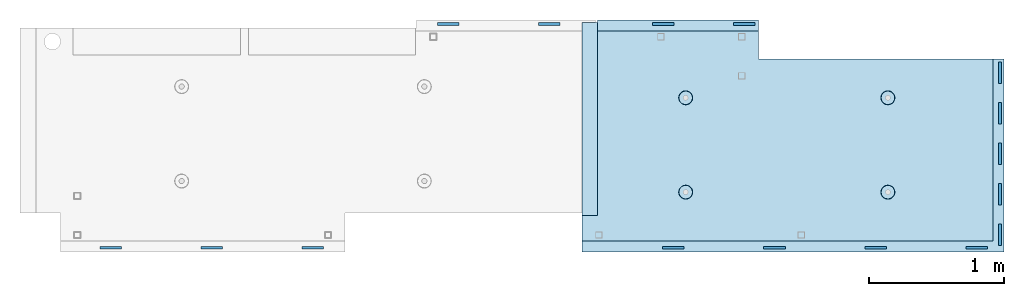
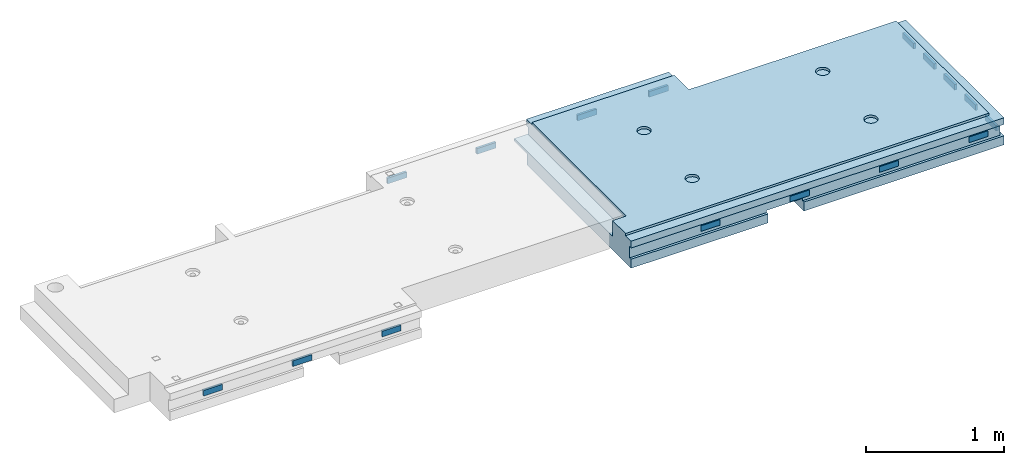
# One storey, part 3 of 3: 16 plates, 1 slab, 18 elements without a shape of their own.
"""IFC2X3 building model written with IfcOpenShell, lengths in millimetres."""

from ifc_helpers import new_model, si_unit, frame, origin_with_axes, place, context, subcontext, project, spatial, faceted_brep, material, type_object, element, aggregate, save


model = new_model("IFC2X3")

# Units and contexts
model_context = context("Model", 3, precision=1e-05, world=origin_with_axes())
body_context = subcontext(model_context, "Body", "Model", "MODEL_VIEW")
ifc_project = project(units=[si_unit("LENGTHUNIT", "METRE", prefix="MILLI"), si_unit("AREAUNIT", "SQUARE_METRE"), si_unit("VOLUMEUNIT", "CUBIC_METRE"), si_unit("MASSUNIT", "GRAM", prefix="KILO"), si_unit("TIMEUNIT", "SECOND"), si_unit("PLANEANGLEUNIT", "RADIAN"), si_unit("SOLIDANGLEUNIT", "STERADIAN"), si_unit("THERMODYNAMICTEMPERATUREUNIT", "DEGREE_CELSIUS"), si_unit("LUMINOUSINTENSITYUNIT", "LUMEN")], contexts=[model_context])

# Site, building, storey
site_placement = place(None, origin_with_axes())
site = spatial("IfcSite", under=ifc_project, at=site_placement, CompositionType="ELEMENT")
building_placement = place(site_placement, origin_with_axes())
building = spatial("IfcBuilding", under=site, at=building_placement, Name="Undefined", CompositionType="ELEMENT")
storey_placement = place(building_placement, origin_with_axes())
storey = spatial("IfcBuildingStorey", under=building, at=storey_placement, Name="3", CompositionType="ELEMENT", Elevation=0.0)

# Assemblies, plates
assembly_1_placement = place(storey_placement, origin_with_axes())
assembly_1 = element("IfcElementAssembly", 1, at=assembly_1_placement, inside=storey, AssemblyPlace="NOTDEFINED", PredefinedType="REINFORCEMENT_UNIT")
assembly_2_placement = place(assembly_1_placement, origin_with_axes())
assembly_2 = element("IfcElementAssembly", 2, at=assembly_2_placement, Name="Steel Assembly", AssemblyPlace="NOTDEFINED", PredefinedType="RIGID_FRAME")
ifc_material_1 = material(Name="STEEL/Steel_Undefined")
plate_type = type_object("IfcPlateType", PredefinedType="NOTDEFINED")
plate_1_placement = place(assembly_2_placement, frame((26530.0042242562, 15347.4967352626, 90645.0), z_axis=(0.999999999999282, 1.19800000174933e-06, 0.0), x_axis=(0.0, 0.0, -1.0)))
plate_1 = element("IfcPlate", 3, at=plate_1_placement, type_object=plate_type, material=ifc_material_1, Name="VL_080", context=body_context, shape_type="Brep", body=[
    faceted_brep([(0.0, -80.0, 0.0), (0.0, -80.0, 20.0), (0.0, 80.0, 20.0), (0.0, 80.0, 0.0), (50.0, -80.0, 20.0), (50.0, 80.0, 20.0), (50.0, -80.0, 0.0), (50.0, 80.0, 0.0)], [[[0, 1, 2, 3]], [[1, 4, 5, 2]], [[4, 6, 7, 5]], [[6, 0, 3, 7]], [[5, 7, 3, 2]], [[6, 4, 1, 0]]]),
])
aggregate(assembly_2, [plate_1])
assembly_3_placement = place(assembly_1_placement, origin_with_axes())
assembly_3 = element("IfcElementAssembly", 4, at=assembly_3_placement, Name="Steel Assembly", AssemblyPlace="NOTDEFINED", PredefinedType="RIGID_FRAME")
plate_2_placement = place(assembly_3_placement, frame((26530.0042242563, 15647.4967352626, 90645.0), z_axis=(0.999999999999282, 1.19800000174933e-06, 0.0), x_axis=(0.0, 0.0, -1.0)))
plate_2 = element("IfcPlate", 5, at=plate_2_placement, type_object=plate_type, material=ifc_material_1, Name="VL_080", context=body_context, shape_type="Brep", body=[
    faceted_brep([(0.0, -80.0, 0.0), (0.0, -80.0, 20.0), (0.0, 80.0, 20.0), (0.0, 80.0, 0.0), (50.0, -80.0, 20.0), (50.0, 80.0, 20.0), (50.0, -80.0, 0.0), (50.0, 80.0, 0.0)], [[[0, 1, 2, 3]], [[1, 4, 5, 2]], [[4, 6, 7, 5]], [[6, 0, 3, 7]], [[5, 7, 3, 2]], [[6, 4, 1, 0]]]),
])
aggregate(assembly_3, [plate_2])
assembly_4_placement = place(assembly_1_placement, origin_with_axes())
assembly_4 = element("IfcElementAssembly", 6, at=assembly_4_placement, Name="Steel Assembly", AssemblyPlace="NOTDEFINED", PredefinedType="RIGID_FRAME")
plate_3_placement = place(assembly_4_placement, frame((26530.0042242564, 15947.4967352626, 90645.0), z_axis=(0.999999999999282, 1.19800000174933e-06, 0.0), x_axis=(0.0, 0.0, -1.0)))
plate_3 = element("IfcPlate", 7, at=plate_3_placement, type_object=plate_type, material=ifc_material_1, Name="VL_080", context=body_context, shape_type="Brep", body=[
    faceted_brep([(0.0, -80.0, 0.0), (0.0, -80.0, 20.0), (0.0, 80.0, 20.0), (0.0, 80.0, 0.0), (50.0, -80.0, 20.0), (50.0, 80.0, 20.0), (50.0, -80.0, 0.0), (50.0, 80.0, 0.0)], [[[0, 1, 2, 3]], [[1, 4, 5, 2]], [[4, 6, 7, 5]], [[6, 0, 3, 7]], [[5, 7, 3, 2]], [[6, 4, 1, 0]]]),
])
aggregate(assembly_4, [plate_3])

assembly_5_placement = place(storey_placement, origin_with_axes())
assembly_5 = element("IfcElementAssembly", 8, at=assembly_5_placement, inside=storey, AssemblyPlace="NOTDEFINED", PredefinedType="REINFORCEMENT_UNIT")
assembly_6_placement = place(assembly_5_placement, origin_with_axes())
assembly_6 = element("IfcElementAssembly", 9, at=assembly_6_placement, Name="Steel Assembly", AssemblyPlace="NOTDEFINED", PredefinedType="RIGID_FRAME")
plate_4_placement = place(assembly_6_placement, frame((19942.4996278758, 15260.0015053437, 90645.0000000001), z_axis=(0.0, -1.0, 0.0), x_axis=(0.0, 0.0, -1.0)))
plate_4 = element("IfcPlate", 10, at=plate_4_placement, type_object=plate_type, material=ifc_material_1, Name="VL_080", context=body_context, shape_type="Brep", body=[
    faceted_brep([(0.0, -80.0, 0.0), (0.0, -80.0, 20.0), (0.0, 80.0, 20.0), (0.0, 80.0, 0.0), (50.0, -80.0, 20.0), (50.0, 80.0, 20.0), (50.0, -80.0, 0.0), (50.0, 80.0, 0.0)], [[[0, 1, 2, 3]], [[1, 4, 5, 2]], [[4, 6, 7, 5]], [[6, 0, 3, 7]], [[5, 7, 3, 2]], [[6, 4, 1, 0]]]),
])
aggregate(assembly_6, [plate_4])
assembly_7_placement = place(assembly_5_placement, origin_with_axes())
assembly_7 = element("IfcElementAssembly", 11, at=assembly_7_placement, Name="Steel Assembly", AssemblyPlace="NOTDEFINED", PredefinedType="RIGID_FRAME")
plate_5_placement = place(assembly_7_placement, frame((20692.4996278758, 15260.0015053437, 90645.0000000001), z_axis=(0.0, -1.0, 0.0), x_axis=(0.0, 0.0, -1.0)))
plate_5 = element("IfcPlate", 12, at=plate_5_placement, type_object=plate_type, material=ifc_material_1, Name="VL_080", context=body_context, shape_type="Brep", body=[
    faceted_brep([(0.0, -80.0, 0.0), (0.0, -80.0, 20.0), (0.0, 80.0, 20.0), (0.0, 80.0, 0.0), (50.0, -80.0, 20.0), (50.0, 80.0, 20.0), (50.0, -80.0, 0.0), (50.0, 80.0, 0.0)], [[[0, 1, 2, 3]], [[1, 4, 5, 2]], [[4, 6, 7, 5]], [[6, 0, 3, 7]], [[5, 7, 3, 2]], [[6, 4, 1, 0]]]),
])
aggregate(assembly_7, [plate_5])
assembly_8_placement = place(assembly_5_placement, origin_with_axes())
assembly_8 = element("IfcElementAssembly", 13, at=assembly_8_placement, Name="Steel Assembly", AssemblyPlace="NOTDEFINED", PredefinedType="RIGID_FRAME")
plate_6_placement = place(assembly_8_placement, frame((21442.4996278758, 15260.0015053437, 90645.0000000001), z_axis=(0.0, -1.0, 0.0), x_axis=(0.0, 0.0, -1.0)))
plate_6 = element("IfcPlate", 14, at=plate_6_placement, type_object=plate_type, material=ifc_material_1, Name="VL_080", context=body_context, shape_type="Brep", body=[
    faceted_brep([(0.0, -80.0, 0.0), (0.0, -80.0, 20.0), (0.0, 80.0, 20.0), (0.0, 80.0, 0.0), (50.0, -80.0, 20.0), (50.0, 80.0, 20.0), (50.0, -80.0, 0.0), (50.0, 80.0, 0.0)], [[[0, 1, 2, 3]], [[1, 4, 5, 2]], [[4, 6, 7, 5]], [[6, 0, 3, 7]], [[5, 7, 3, 2]], [[6, 4, 1, 0]]]),
])
aggregate(assembly_8, [plate_6])
assembly_9_placement = place(assembly_5_placement, origin_with_axes())
assembly_9 = element("IfcElementAssembly", 15, at=assembly_9_placement, Name="Steel Assembly", AssemblyPlace="NOTDEFINED", PredefinedType="RIGID_FRAME")
plate_7_placement = place(assembly_9_placement, frame((23197.5104945185, 16900.0074175624, 90645.0000000001), z_axis=(0.0, 1.0, 0.0), x_axis=(0.0, 0.0, -1.0)))
plate_7 = element("IfcPlate", 16, at=plate_7_placement, type_object=plate_type, material=ifc_material_1, Name="VL_080", context=body_context, shape_type="Brep", body=[
    faceted_brep([(0.0, -80.0, 0.0), (0.0, -80.0, 20.0), (0.0, 80.0, 20.0), (0.0, 80.0, 0.0), (50.0, -80.0, 20.0), (50.0, 80.0, 20.0), (50.0, -80.0, 0.0), (50.0, 80.0, 0.0)], [[[0, 1, 2, 3]], [[1, 4, 5, 2]], [[4, 6, 7, 5]], [[6, 0, 3, 7]], [[5, 7, 3, 2]], [[6, 4, 1, 0]]]),
])
aggregate(assembly_9, [plate_7])
assembly_10_placement = place(assembly_5_placement, origin_with_axes())
assembly_10 = element("IfcElementAssembly", 17, at=assembly_10_placement, Name="Steel Assembly", AssemblyPlace="NOTDEFINED", PredefinedType="RIGID_FRAME")
aggregate(assembly_5, [assembly_6, assembly_7, assembly_8, assembly_9, assembly_10])
plate_8_placement = place(assembly_10_placement, frame((22447.5104945185, 16900.0074175624, 90645.0000000001), z_axis=(0.0, 1.0, 0.0), x_axis=(0.0, 0.0, -1.0)))
plate_8 = element("IfcPlate", 18, at=plate_8_placement, type_object=plate_type, material=ifc_material_1, Name="VL_080", context=body_context, shape_type="Brep", body=[
    faceted_brep([(0.0, -80.0, 0.0), (0.0, -80.0, 20.0), (0.0, 80.0, 20.0), (0.0, 80.0, 0.0), (50.0, -80.0, 20.0), (50.0, 80.0, 20.0), (50.0, -80.0, 0.0), (50.0, 80.0, 0.0)], [[[0, 1, 2, 3]], [[1, 4, 5, 2]], [[4, 6, 7, 5]], [[6, 0, 3, 7]], [[5, 7, 3, 2]], [[6, 4, 1, 0]]]),
])
aggregate(assembly_10, [plate_8])

# Assembly, plate
assembly_11_placement = place(assembly_1_placement, origin_with_axes())
assembly_11 = element("IfcElementAssembly", 19, at=assembly_11_placement, Name="Steel Assembly", AssemblyPlace="NOTDEFINED", PredefinedType="RIGID_FRAME")
plate_9_placement = place(assembly_11_placement, frame((24117.5026062248, 15259.9935155938, 90645.0000000001), z_axis=(0.0, -1.0, 0.0), x_axis=(0.0, 0.0, -1.0)))
plate_9 = element("IfcPlate", 20, at=plate_9_placement, type_object=plate_type, material=ifc_material_1, Name="VL_080", context=body_context, shape_type="Brep", body=[
    faceted_brep([(0.0, -80.0, 0.0), (0.0, -80.0, 20.0), (0.0, 80.0, 20.0), (0.0, 80.0, 0.0), (50.0, -80.0, 20.0), (50.0, 80.0, 20.0), (50.0, -80.0, 0.0), (50.0, 80.0, 0.0)], [[[0, 1, 2, 3]], [[1, 4, 5, 2]], [[4, 6, 7, 5]], [[6, 0, 3, 7]], [[5, 7, 3, 2]], [[6, 4, 1, 0]]]),
])
aggregate(assembly_11, [plate_9])

assembly_12_placement = place(assembly_1_placement, origin_with_axes())
assembly_12 = element("IfcElementAssembly", 21, at=assembly_12_placement, Name="Steel Assembly", AssemblyPlace="NOTDEFINED", PredefinedType="RIGID_FRAME")
plate_10_placement = place(assembly_12_placement, frame((24867.5026062248, 15259.9946938464, 90645.0000000001), z_axis=(0.0, -1.0, 0.0), x_axis=(0.0, 0.0, -1.0)))
plate_10 = element("IfcPlate", 22, at=plate_10_placement, type_object=plate_type, material=ifc_material_1, Name="VL_080", context=body_context, shape_type="Brep", body=[
    faceted_brep([(0.0, -80.0, 0.0), (0.0, -80.0, 20.0), (0.0, 80.0, 20.0), (0.0, 80.0, 0.0), (50.0, -80.0, 20.0), (50.0, 80.0, 20.0), (50.0, -80.0, 0.0), (50.0, 80.0, 0.0)], [[[0, 1, 2, 3]], [[1, 4, 5, 2]], [[4, 6, 7, 5]], [[6, 0, 3, 7]], [[5, 7, 3, 2]], [[6, 4, 1, 0]]]),
])
aggregate(assembly_12, [plate_10])

assembly_13_placement = place(assembly_1_placement, origin_with_axes())
assembly_13 = element("IfcElementAssembly", 23, at=assembly_13_placement, Name="Steel Assembly", AssemblyPlace="NOTDEFINED", PredefinedType="RIGID_FRAME")
plate_11_placement = place(assembly_13_placement, frame((25617.5026062248, 15259.9958720982, 90645.0000000001), z_axis=(0.0, -1.0, 0.0), x_axis=(0.0, 0.0, -1.0)))
plate_11 = element("IfcPlate", 24, at=plate_11_placement, type_object=plate_type, material=ifc_material_1, Name="VL_080", context=body_context, shape_type="Brep", body=[
    faceted_brep([(0.0, -80.0, 0.0), (0.0, -80.0, 20.0), (0.0, 80.0, 20.0), (0.0, 80.0, 0.0), (50.0, -80.0, 20.0), (50.0, 80.0, 20.0), (50.0, -80.0, 0.0), (50.0, 80.0, 0.0)], [[[0, 1, 2, 3]], [[1, 4, 5, 2]], [[4, 6, 7, 5]], [[6, 0, 3, 7]], [[5, 7, 3, 2]], [[6, 4, 1, 0]]]),
])
aggregate(assembly_13, [plate_11])

assembly_14_placement = place(assembly_1_placement, origin_with_axes())
assembly_14 = element("IfcElementAssembly", 25, at=assembly_14_placement, Name="Steel Assembly", AssemblyPlace="NOTDEFINED", PredefinedType="RIGID_FRAME")
plate_12_placement = place(assembly_14_placement, frame((26367.5026062248, 15259.9970503508, 90645.0000000001), z_axis=(0.0, -1.0, 0.0), x_axis=(0.0, 0.0, -1.0)))
plate_12 = element("IfcPlate", 26, at=plate_12_placement, type_object=plate_type, material=ifc_material_1, Name="VL_080", context=body_context, shape_type="Brep", body=[
    faceted_brep([(0.0, -80.0, 0.0), (0.0, -80.0, 20.0), (0.0, 80.0, 20.0), (0.0, 80.0, 0.0), (50.0, -80.0, 20.0), (50.0, 80.0, 20.0), (50.0, -80.0, 0.0), (50.0, 80.0, 0.0)], [[[0, 1, 2, 3]], [[1, 4, 5, 2]], [[4, 6, 7, 5]], [[6, 0, 3, 7]], [[5, 7, 3, 2]], [[6, 4, 1, 0]]]),
])
aggregate(assembly_14, [plate_12])

assembly_15_placement = place(assembly_1_placement, origin_with_axes())
assembly_15 = element("IfcElementAssembly", 27, at=assembly_15_placement, Name="Steel Assembly", AssemblyPlace="NOTDEFINED", PredefinedType="RIGID_FRAME")
plate_13_placement = place(assembly_15_placement, frame((24642.5073730503, 16900.0041574535, 90645.0000000001), z_axis=(0.0, 1.0, 0.0), x_axis=(0.0, 0.0, -1.0)))
plate_13 = element("IfcPlate", 28, at=plate_13_placement, type_object=plate_type, material=ifc_material_1, Name="VL_080", context=body_context, shape_type="Brep", body=[
    faceted_brep([(0.0, -80.0, 0.0), (0.0, -80.0, 20.0), (0.0, 80.0, 20.0), (0.0, 80.0, 0.0), (50.0, -80.0, 20.0), (50.0, 80.0, 20.0), (50.0, -80.0, 0.0), (50.0, 80.0, 0.0)], [[[0, 1, 2, 3]], [[1, 4, 5, 2]], [[4, 6, 7, 5]], [[6, 0, 3, 7]], [[5, 7, 3, 2]], [[6, 4, 1, 0]]]),
])
aggregate(assembly_15, [plate_13])

assembly_16_placement = place(assembly_1_placement, origin_with_axes())
assembly_16 = element("IfcElementAssembly", 29, at=assembly_16_placement, Name="Steel Assembly", AssemblyPlace="NOTDEFINED", PredefinedType="RIGID_FRAME")
plate_14_placement = place(assembly_16_placement, frame((24042.5073730503, 16900.0029792012, 90645.0000000001), z_axis=(0.0, 1.0, 0.0), x_axis=(0.0, 0.0, -1.0)))
plate_14 = element("IfcPlate", 30, at=plate_14_placement, type_object=plate_type, material=ifc_material_1, Name="VL_080", context=body_context, shape_type="Brep", body=[
    faceted_brep([(0.0, -80.0, 0.0), (0.0, -80.0, 20.0), (0.0, 80.0, 20.0), (0.0, 80.0, 0.0), (50.0, -80.0, 20.0), (50.0, 80.0, 20.0), (50.0, -80.0, 0.0), (50.0, 80.0, 0.0)], [[[0, 1, 2, 3]], [[1, 4, 5, 2]], [[4, 6, 7, 5]], [[6, 0, 3, 7]], [[5, 7, 3, 2]], [[6, 4, 1, 0]]]),
])
aggregate(assembly_16, [plate_14])

assembly_17_placement = place(assembly_1_placement, origin_with_axes())
assembly_17 = element("IfcElementAssembly", 31, at=assembly_17_placement, Name="Steel Assembly", AssemblyPlace="NOTDEFINED", PredefinedType="RIGID_FRAME")
plate_15_placement = place(assembly_17_placement, frame((26530.0041260693, 16247.496703842, 90645.0), z_axis=(0.999999999993412, 3.63000011325366e-06, 0.0), x_axis=(0.0, 0.0, -1.0)))
plate_15 = element("IfcPlate", 32, at=plate_15_placement, type_object=plate_type, material=ifc_material_1, Name="VL_080", context=body_context, shape_type="Brep", body=[
    faceted_brep([(0.0, -80.0, 0.0), (0.0, -80.0, 20.0), (0.0, 80.0, 20.0), (0.0, 80.0, 0.0), (50.0, -80.0, 20.0), (50.0, 80.0, 20.0), (50.0, -80.0, 0.0), (50.0, 80.0, 0.0)], [[[0, 1, 2, 3]], [[1, 4, 5, 2]], [[4, 6, 7, 5]], [[6, 0, 3, 7]], [[5, 7, 3, 2]], [[6, 4, 1, 0]]]),
])
aggregate(assembly_17, [plate_15])

assembly_18_placement = place(assembly_1_placement, origin_with_axes())
assembly_18 = element("IfcElementAssembly", 33, at=assembly_18_placement, Name="Steel Assembly", AssemblyPlace="NOTDEFINED", PredefinedType="RIGID_FRAME")
plate_16_placement = place(assembly_18_placement, frame((26530.0041260692, 16547.496703842, 90645.0), z_axis=(0.999999999993412, 3.63000011325366e-06, 0.0), x_axis=(0.0, 0.0, -1.0)))
plate_16 = element("IfcPlate", 34, at=plate_16_placement, type_object=plate_type, material=ifc_material_1, Name="VL_080", context=body_context, shape_type="Brep", body=[
    faceted_brep([(0.0, -80.0, 0.0), (0.0, -80.0, 20.0), (0.0, 80.0, 20.0), (0.0, 80.0, 0.0), (50.0, -80.0, 20.0), (50.0, 80.0, 20.0), (50.0, -80.0, 0.0), (50.0, 80.0, 0.0)], [[[0, 1, 2, 3]], [[1, 4, 5, 2]], [[4, 6, 7, 5]], [[6, 0, 3, 7]], [[5, 7, 3, 2]], [[6, 4, 1, 0]]]),
])
aggregate(assembly_18, [plate_16])

# Slab
ifc_material_2 = material(Name="CONCRETE/C25/30")
slab_type = type_object("IfcSlabType", PredefinedType="NOTDEFINED")
slab_placement = place(assembly_1_placement, frame((26570.0059390845, 15220.0026483125, 90620.0), z_axis=(-0.999999999997437, -2.26400000064461e-06, 0.0), x_axis=(-1.19799915409591e-06, 0.999999999999282, 0.0)))
slab = element("IfcSlab", 35, at=slab_placement, type_object=slab_type, material=ifc_material_2, PredefinedType="FLOOR", context=body_context, shape_type="Brep", body=[
    faceted_brep([(260.000036693442, 30.0, 20.0001116859203), (260.00040878505, 30.0, 210.00282380305), (760.000392750888, 30.0, 210.001882803081), (760.000035167954, 30.0, 20.0003241859195), (259.999997532928, 50.0008466322761, 0.000110715616756352), (259.999997531775, 130.0, 4.72937244921923e-11), (260.00040878505, 130.0, 210.00282380305), (260.00003669344, 50.0008466322906, 20.0001116859239), (760.000392750888, 130.0, 210.001882803081), (759.999997530887, 50.0009701322706, 0.00188280345173553), (760.000035167954, 50.0009701322851, 20.0003241859267), (759.999997530887, 130.0, 1.4915713109076e-10), (0.0, 130.0, -1.81898940354586e-12), (0.0, 50.0007830199902, -3.63797880709171e-12), (2.23492861550767e-06, 50.0007830199902, 20.0000012144774), (0.00314200731554592, 50.0009709416772, 1679.99820316408), (0.00316042736994859, 130.0, 1679.99820316404), (20.0042037197236, 50.0007871208509, 20.0000019346335), (20.0050448999082, 50.0009732451872, 1679.9981655205), (20.0051981998968, 30.0, 1979.99816552074), (210.003723882246, 30.0, 1979.99780794351), (210.003159282247, 30.0, 1679.99780794404), (20.0050448999027, 30.0, 1679.9981655205), (20.0057858500695, 50.0011356208415, 3129.99855788155), (0.00588817475545511, 50.0011356208415, 3129.99536132812), (0.00371018100122456, 50.0010050132987, 1979.99820316354), (20.0051981998986, 50.0010068401461, 1979.99816552074), (1720.00727399273, -49.9988643791585, 3014.99216831216), (1700.0058891816, -49.9988643791585, 3014.99217713277), (1700.0058891816, 9.99999999994179, 3014.99217713277), (270.007273993393, 9.99999999994179, 3014.99280776216), (270.007273993393, -130.000000000058, 3014.99280776216), (1640.00591170533, -130.000000000058, 3014.99220359276), (1640.00591170533, -110.000000000058, 3014.99220359276), (1720.00727399273, -110.000000000058, 3014.99216831216), (1700.00578510373, 9.99999999994179, 3129.99536132812), (270.007324709519, 9.99999999994179, 3129.99536132812), (1700.00588013352, 9.99999999994179, 3024.99005271558), (270.007324709519, -130.0, 3129.99536132812), (0.0, -49.9992169800098, -3.63797880709171e-12), (1.81898940354586e-12, -110.000000000058, 0.0), (0.00588817475545511, -110.0, 3129.99536132812), (0.00588817475545511, -49.9988643791585, 3129.99536132812), (2.27349282795331e-05, -49.9992169800098, 20.000001214441), (40.0000000237706, -110.0, 0.00323799208854325), (40.0000056179106, -110.0, 80.000116817555), (80.0001648500238, -110.0, 80.0001140175445), (80.0058896111077, -110.0, 3129.99536132811), (80.0001648500238, -130.0, 80.0001140175445), (80.0058896111077, -130.0, 3129.99536132812), (458.262860973307, -110.000000000015, 813.90255309167), (472.201273869185, -110.000000000015, 821.004529187678), (483.262860973307, -110.000000000015, 832.066116291804), (490.364837069317, -110.000000000015, 846.004529187678), (492.812011254558, -110.000000000015, 861.455378906427), (490.364837069317, -110.000000000015, 876.906228625172), (483.262860973307, -110.000000000015, 890.844641521049), (472.201273869185, -110.000000000015, 901.906228625176), (458.262860973306, -110.000000000015, 909.008204721184), (442.81201125456, -110.000000000015, 911.455378906427), (427.361161535811, -110.000000000015, 909.008204721184), (413.422748639936, -110.000000000015, 901.906228625176), (402.361161535813, -110.000000000015, 890.844641521046), (395.259185439802, -110.000000000015, 876.906228625176), (392.81201125456, -110.000000000015, 861.455378906427), (395.259185439802, -110.000000000015, 846.004529187681), (402.361161535813, -110.000000000015, 832.0661162918), (413.422748639936, -110.000000000015, 821.004529187678), (427.361161535813, -110.000000000015, 813.90255309167), (442.812011254558, -110.000000000015, 811.455378906427), (458.965172324157, -130.0, 811.741061009179), (442.812011254558, -130.0, 809.182651633699), (473.537149442574, -130.0, 819.165854200462), (485.101535960521, -130.0, 830.730240718414), (492.526329151806, -130.0, 845.302217836826), (495.084738527285, -130.0, 861.45537890643), (492.526329151804, -130.0, 877.608539976027), (485.101535960521, -130.0, 892.180517094443), (473.537149442574, -130.0, 903.744903612387), (458.965172324157, -130.0, 911.16969680367), (442.81201125456, -130.0, 913.728106179151), (426.658850184962, -130.0, 911.169696803674), (412.086873066544, -130.0, 903.744903612391), (400.522486548598, -130.0, 892.180517094443), (393.097693357315, -130.0, 877.608539976027), (390.539283981834, -130.0, 861.455378906427), (393.097693357317, -130.0, 845.302217836826), (400.522486548598, -130.0, 830.730240718414), (412.086873066544, -130.0, 819.165854200462), (426.658850184962, -130.0, 811.741061009183), (1158.26361347154, -110.000000000058, 2313.90608356011), (1172.20202636741, -110.000000000058, 2321.00805965612), (1183.26361347154, -110.000000000058, 2332.06964676024), (1190.36558956755, -110.000000000058, 2346.00805965611), (1192.81276375279, -110.000000000058, 2361.45890937486), (1190.36558956755, -110.000000000058, 2376.90975909361), (1183.26361347154, -110.000000000058, 2390.84817198949), (1172.20202636741, -110.000000000058, 2401.90975909361), (1158.26361347154, -110.000000000058, 2409.01173518962), (1142.81276375279, -110.000000000058, 2411.45890937487), (1127.36191403404, -110.000000000058, 2409.01173518962), (1113.42350113817, -110.000000000058, 2401.90975909361), (1102.36191403404, -110.000000000058, 2390.84817198948), (1095.25993793803, -110.000000000058, 2376.90975909361), (1092.81276375279, -110.000000000058, 2361.45890937486), (1095.25993793803, -110.000000000058, 2346.00805965612), (1102.36191403404, -110.000000000058, 2332.06964676024), (1113.42350113817, -110.000000000058, 2321.00805965611), (1127.36191403405, -110.000000000058, 2313.90608356011), (1142.81276375279, -110.000000000058, 2311.45890937486), (1158.96592482239, -130.000000000044, 2311.74459147762), (1142.81276375279, -130.000000000044, 2309.18618210214), (1173.5379019408, -130.000000000044, 2319.1693846689), (1185.10228845875, -130.000000000044, 2330.73377118685), (1192.52708165004, -130.000000000044, 2345.30574830526), (1195.08549102551, -130.000000000044, 2361.45890937486), (1192.52708165004, -130.000000000044, 2377.61207044447), (1185.10228845875, -130.000000000044, 2392.18404756288), (1173.5379019408, -130.000000000044, 2403.74843408083), (1158.96592482239, -130.000000000044, 2411.17322727211), (1142.81276375279, -130.000000000044, 2413.73163664759), (1126.65960268319, -130.000000000044, 2411.17322727211), (1112.08762556478, -130.000000000044, 2403.74843408083), (1100.52323904683, -130.000000000044, 2392.18404756287), (1093.09844585554, -130.000000000044, 2377.61207044447), (1090.54003648007, -130.000000000044, 2361.45890937486), (1093.09844585555, -130.000000000044, 2345.30574830526), (1100.52323904683, -130.000000000044, 2330.73377118685), (1112.08762556478, -130.000000000044, 2319.1693846689), (1126.65960268319, -130.000000000044, 2311.74459147762), (1158.26322681425, -110.000000000029, 813.902566246979), (1172.20163971013, -110.000000000029, 821.004542342987), (1183.26322681425, -110.000000000029, 832.066129447114), (1190.36520291026, -110.000000000029, 846.004542342987), (1192.8123770955, -110.000000000029, 861.455392061736), (1190.36520291026, -110.000000000029, 876.906241780482), (1183.26322681425, -110.000000000029, 890.844654676363), (1172.20163971012, -110.000000000029, 901.906241780485), (1158.26322681425, -110.000000000029, 909.008217876493), (1142.8123770955, -110.000000000029, 911.455392061736), (1127.36152737675, -110.000000000029, 909.008217876493), (1113.42311448088, -110.000000000029, 901.906241780485), (1102.36152737675, -110.000000000029, 890.844654676359), (1095.25955128074, -110.000000000029, 876.906241780485), (1092.8123770955, -110.000000000029, 861.45539206174), (1095.25955128074, -110.000000000029, 846.004542342991), (1102.36152737675, -110.000000000029, 832.06612944711), (1113.42311448088, -110.000000000029, 821.004542342987), (1127.36152737675, -110.000000000029, 813.902566246979), (1142.8123770955, -110.000000000029, 811.455392061736), (1158.9655381651, -130.000000000029, 811.741074164489), (1142.8123770955, -130.000000000029, 809.182664789012), (1173.53751528352, -130.000000000029, 819.165867355772), (1185.10190180146, -130.000000000029, 830.730253873724), (1192.52669499275, -130.000000000029, 845.302230992136), (1195.08510436823, -130.000000000029, 861.45539206174), (1192.52669499275, -130.000000000029, 877.608553131337), (1185.10190180146, -130.000000000029, 892.180530249756), (1173.53751528351, -130.000000000029, 903.744916767697), (1158.9655381651, -130.000000000029, 911.16970995898), (1142.8123770955, -130.000000000029, 913.728119334461), (1126.6592160259, -130.000000000029, 911.169709958984), (1112.08723890749, -130.000000000029, 903.7449167677), (1100.52285238954, -130.000000000029, 892.180530249752), (1093.09805919825, -130.000000000029, 877.608553131337), (1090.53964982277, -130.000000000015, 861.455392061736), (1093.09805919826, -130.000000000015, 845.302230992136), (1100.52285238954, -130.000000000015, 830.730253873724), (1112.08723890749, -130.000000000015, 819.165867355776), (1126.6592160259, -130.000000000015, 811.741074164493), (458.263613472778, -110.000000000058, 2313.90740096011), (472.202026368655, -110.000000000058, 2321.00937705611), (483.263613472776, -110.000000000058, 2332.07096416024), (490.365589568788, -110.000000000058, 2346.00937705611), (492.812763754029, -110.000000000058, 2361.46022677486), (490.365589568788, -110.000000000058, 2376.91107649361), (483.263613472778, -110.000000000058, 2390.84948938949), (472.202026368655, -110.000000000058, 2401.91107649361), (458.263613472776, -110.000000000058, 2409.01305258962), (442.812763754029, -110.000000000058, 2411.46022677486), (427.361914035282, -110.000000000058, 2409.01305258962), (413.423501139407, -110.000000000058, 2401.91107649361), (402.361914035284, -110.000000000058, 2390.84948938949), (395.259937939272, -110.000000000058, 2376.91107649361), (392.812763754031, -110.000000000058, 2361.46022677486), (395.259937939272, -110.000000000058, 2346.00937705612), (402.361914035284, -110.000000000058, 2332.07096416024), (413.423501139407, -110.000000000058, 2321.00937705611), (427.361914035284, -110.000000000058, 2313.90740096011), (442.812763754029, -110.000000000058, 2311.46022677486), (458.965924823628, -130.000000000029, 2311.74590887762), (442.812763754029, -130.000000000029, 2309.18749950214), (473.537901942043, -130.000000000029, 2319.1707020689), (485.10228845999, -130.000000000029, 2330.73508858685), (492.527081651273, -130.000000000029, 2345.30706570526), (495.085491026754, -130.000000000029, 2361.46022677486), (492.527081651273, -130.000000000029, 2377.61338784446), (485.102288459992, -130.000000000029, 2392.18536496288), (473.537901942043, -130.000000000029, 2403.74975148082), (458.965924823628, -130.000000000029, 2411.1745446721), (442.812763754031, -130.000000000029, 2413.73295404758), (426.659602684433, -130.000000000029, 2411.17454467211), (412.087625566017, -130.000000000029, 2403.74975148082), (400.523239048071, -130.000000000029, 2392.18536496288), (393.098445856787, -130.000000000029, 2377.61338784446), (390.540036481307, -130.000000000029, 2361.46022677486), (393.098445856789, -130.000000000029, 2345.30706570526), (400.523239048067, -130.000000000029, 2330.73508858685), (412.087625566017, -130.000000000029, 2319.17070206891), (426.659602684433, -130.000000000029, 2311.74590887762), (1640.0069692709, -130.000000000058, 1820.00285259458), (1429.99412576448, -130.0, 80.0005450159842), (1430.00077693619, -130.000000000044, 1820.00324782623), (1640.0069692709, -110.000000000058, 1820.00285259458), (1720.00719314726, -110.000000000058, 1820.00270203416), (1720.00719416424, -49.9988643791585, 1820.00270203415), (1700.00697064704, -49.9988643791585, 1820.00273967458), (1430.00077693619, 129.999999999985, 1820.00324782623), (1720.00507313573, 130.0, 1820.00270203815), (1720.00696350816, 50.0011356208415, 1820.00270203459), (1700.00697064704, 50.0011356208415, 1820.00273967458), (1720.00548380367, 130.0, 2629.9953613439), (1720.00479630696, 50.0011356208415, 2629.99536134425), (1700.00623760369, 50.0011356208415, 2629.99539898154), (1700.00623760369, 30.0, 2629.99539898154), (1700.00578510373, 30.0, 3129.99535793147), (1510.00479630733, 130.0, 2629.99575656425), (1510.00479630733, 30.0, 2629.99575656425), (1510.00573730659, 130.0, 3129.99536132812), (1510.00573730659, 30.0, 3129.99536134176), (0.00588817475545511, 130.0, 3129.99536132812), (20.0057858500695, -49.9988643791585, 3129.99855788155), (0.00372479000361636, 130.0, 1979.99820316351), (210.003723882246, 130.0, 1979.99780794351), (210.003159282247, 130.0, 1679.99780794404), (20.0042037196527, -49.9988643791585, 20.0000019345935), (20.0041864226587, -49.9992128791491, 7.34271452529356e-07), (1429.99419217423, -49.9988643791585, 20.0006089333838), (1429.99420067423, -49.9988643791585, 0.000608933383773547), (80.0000146155362, -110.0, 0.000114017555461032), (1429.99735169022, -110.0, 7.40013310860377e-05), (1429.99412576448, -110.0, 80.0005450159842), (1429.99416747423, 50.0011356208415, 20.0006089334311), (1429.99417597423, 50.0011356208415, 0.000608933431067271), (1429.99735169022, 130.0, 2.80124368146062e-10), (20.0041864225386, 50.0007871208509, -3.03407432511449e-09)], [[[0, 1, 2, 3]], [[4, 5, 6, 1, 0, 7]], [[8, 2, 1, 6]], [[9, 10, 3, 2, 8, 11]], [[12, 13, 14, 15, 16]], [[14, 17, 18, 15]], [[19, 20, 21, 22]], [[23, 24, 25, 26]], [[27, 28, 29, 30, 31, 32, 33, 34]], [[35, 36, 30, 29, 37]], [[31, 30, 36, 38]], [[39, 40, 41, 42, 43]], [[44, 45, 46, 47, 41, 40]], [[48, 49, 47, 46]], [[50, 51, 52, 53, 54, 55, 56, 57, 58, 59, 60, 61, 62, 63, 64, 65, 66, 67, 68, 69]], [[70, 50, 69, 71]], [[72, 51, 50, 70]], [[73, 52, 51, 72]], [[74, 53, 52, 73]], [[75, 54, 53, 74]], [[76, 55, 54, 75]], [[77, 56, 55, 76]], [[78, 57, 56, 77]], [[79, 58, 57, 78]], [[80, 59, 58, 79]], [[81, 60, 59, 80]], [[82, 61, 60, 81]], [[83, 62, 61, 82]], [[84, 63, 62, 83]], [[85, 64, 63, 84]], [[86, 65, 64, 85]], [[87, 66, 65, 86]], [[88, 67, 66, 87]], [[89, 68, 67, 88]], [[71, 69, 68, 89]], [[90, 91, 92, 93, 94, 95, 96, 97, 98, 99, 100, 101, 102, 103, 104, 105, 106, 107, 108, 109]], [[110, 90, 109, 111]], [[112, 91, 90, 110]], [[113, 92, 91, 112]], [[114, 93, 92, 113]], [[115, 94, 93, 114]], [[116, 95, 94, 115]], [[117, 96, 95, 116]], [[118, 97, 96, 117]], [[119, 98, 97, 118]], [[120, 99, 98, 119]], [[121, 100, 99, 120]], [[122, 101, 100, 121]], [[123, 102, 101, 122]], [[124, 103, 102, 123]], [[125, 104, 103, 124]], [[126, 105, 104, 125]], [[127, 106, 105, 126]], [[128, 107, 106, 127]], [[129, 108, 107, 128]], [[111, 109, 108, 129]], [[130, 131, 132, 133, 134, 135, 136, 137, 138, 139, 140, 141, 142, 143, 144, 145, 146, 147, 148, 149]], [[150, 130, 149, 151]], [[152, 131, 130, 150]], [[153, 132, 131, 152]], [[154, 133, 132, 153]], [[155, 134, 133, 154]], [[156, 135, 134, 155]], [[157, 136, 135, 156]], [[158, 137, 136, 157]], [[159, 138, 137, 158]], [[160, 139, 138, 159]], [[161, 140, 139, 160]], [[162, 141, 140, 161]], [[163, 142, 141, 162]], [[164, 143, 142, 163]], [[165, 144, 143, 164]], [[166, 145, 144, 165]], [[167, 146, 145, 166]], [[168, 147, 146, 167]], [[169, 148, 147, 168]], [[151, 149, 148, 169]], [[170, 171, 172, 173, 174, 175, 176, 177, 178, 179, 180, 181, 182, 183, 184, 185, 186, 187, 188, 189]], [[190, 170, 189, 191]], [[192, 171, 170, 190]], [[193, 172, 171, 192]], [[194, 173, 172, 193]], [[195, 174, 173, 194]], [[196, 175, 174, 195]], [[197, 176, 175, 196]], [[198, 177, 176, 197]], [[199, 178, 177, 198]], [[200, 179, 178, 199]], [[201, 180, 179, 200]], [[202, 181, 180, 201]], [[203, 182, 181, 202]], [[204, 183, 182, 203]], [[205, 184, 183, 204]], [[206, 185, 184, 205]], [[207, 186, 185, 206]], [[208, 187, 186, 207]], [[209, 188, 187, 208]], [[191, 189, 188, 209]], [[210, 32, 31, 38, 49, 48, 211, 212], [208, 207, 206, 205, 204, 203, 202, 201, 200, 199, 198, 197, 196, 195, 194, 193, 192, 190, 191, 209], [168, 167, 166, 165, 164, 163, 162, 161, 160, 159, 158, 157, 156, 155, 154, 153, 152, 150, 151, 169], [128, 127, 126, 125, 124, 123, 122, 121, 120, 119, 118, 117, 116, 115, 114, 113, 112, 110, 111, 129], [88, 87, 86, 85, 84, 83, 82, 81, 80, 79, 78, 77, 76, 75, 74, 73, 72, 70, 71, 89]], [[33, 32, 210, 213]], [[34, 33, 213, 214]], [[27, 34, 214, 215]], [[28, 27, 215, 216]], [[214, 213, 210, 212, 217, 218, 219, 220, 216, 215]], [[219, 218, 221, 222]], [[220, 219, 222, 223]], [[35, 37, 29, 28, 216, 220, 223, 224, 225]], [[222, 221, 226, 227, 224, 223]], [[228, 229, 227, 226]], [[224, 227, 229, 225]], [[228, 230, 24, 23, 231, 42, 41, 47, 49, 38, 36, 35, 225, 229]], [[24, 230, 232, 25]], [[233, 20, 19, 26, 25, 232]], [[234, 21, 20, 233]], [[16, 15, 18, 22, 21, 234]], [[17, 235, 231, 23, 26, 19, 22, 18]], [[43, 42, 231, 235]], [[236, 39, 43, 235, 237, 238]], [[239, 44, 40, 39, 236, 238, 240]], [[46, 45, 44, 239, 240, 241]], [[48, 46, 241, 211]], [[240, 238, 237, 242, 243, 244, 217, 212, 211, 241]], [[244, 243, 9, 11]], [[6, 5, 12, 16, 234, 233, 232, 230, 228, 226, 221, 218, 217, 244, 11, 8]], [[245, 13, 12, 5, 4]], [[17, 14, 13, 245, 4, 7]], [[242, 237, 235, 17, 7, 0, 3, 10]], [[243, 242, 10, 9]]]),
])

aggregate(assembly_1, [assembly_2, assembly_3, assembly_4, assembly_11, assembly_12, assembly_13, assembly_14, assembly_15, assembly_16, assembly_17, assembly_18, slab])

save(model, "model.ifc")
